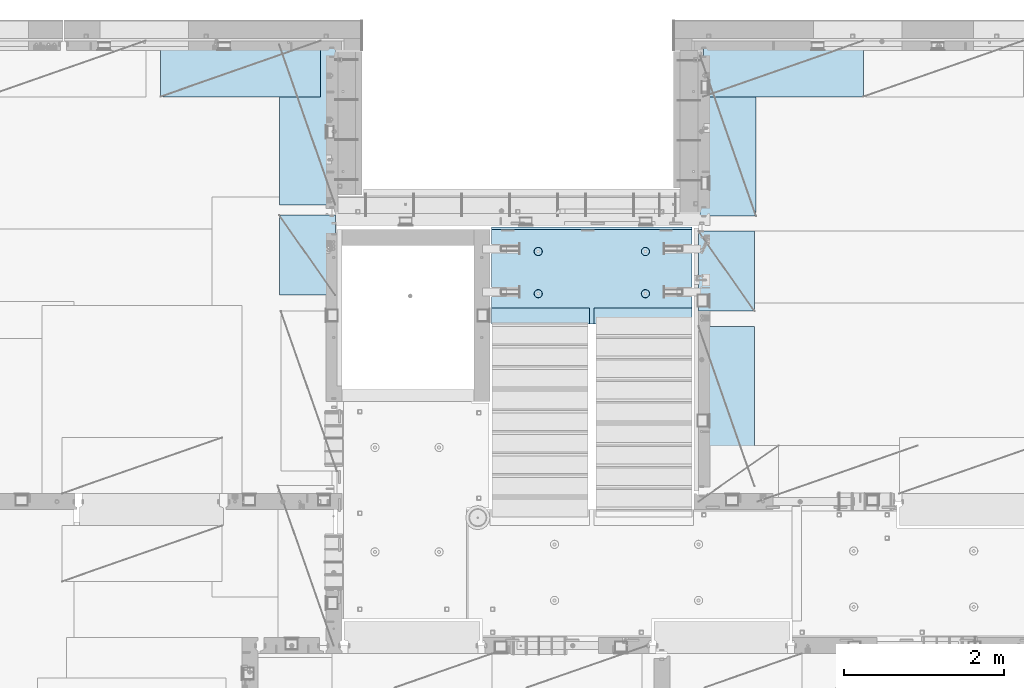
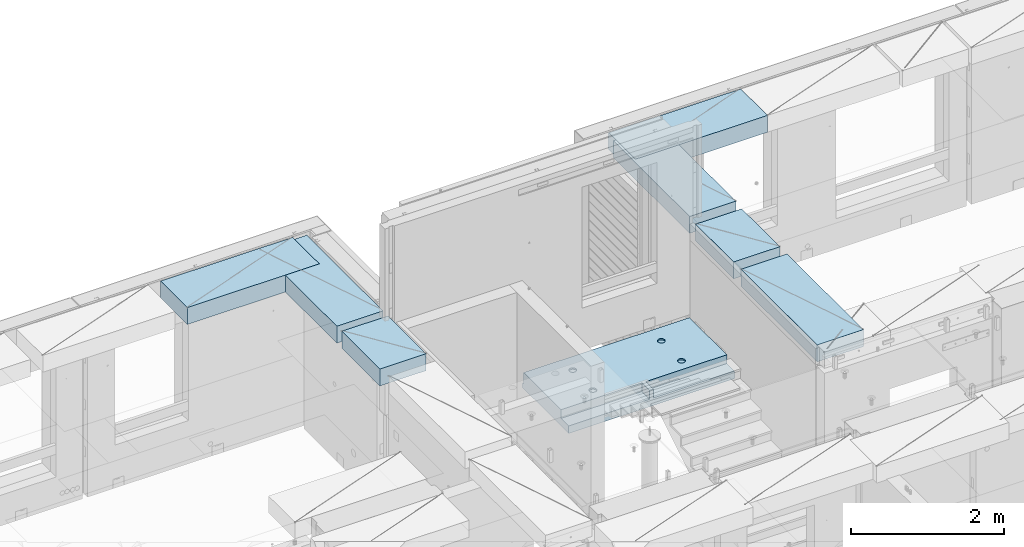
# One storey, part 208 of 349: 7 plates, 1 slab, 8 elements without a shape of their own.
"""IFC2X3 building model written with IfcOpenShell, lengths in millimetres."""

from ifc_helpers import new_model, si_unit, frame, origin_with_axes, place, context, subcontext, project, spatial, faceted_brep, material, type_object, element, aggregate, save


model = new_model("IFC2X3")

# Units and contexts
model_context = context("Model", 3, precision=1e-05, world=origin_with_axes())
body_context = subcontext(model_context, "Body", "Model", "MODEL_VIEW")
ifc_project = project(units=[si_unit("LENGTHUNIT", "METRE", prefix="MILLI"), si_unit("AREAUNIT", "SQUARE_METRE"), si_unit("VOLUMEUNIT", "CUBIC_METRE"), si_unit("MASSUNIT", "GRAM", prefix="KILO"), si_unit("TIMEUNIT", "SECOND"), si_unit("PLANEANGLEUNIT", "RADIAN"), si_unit("SOLIDANGLEUNIT", "STERADIAN"), si_unit("THERMODYNAMICTEMPERATUREUNIT", "DEGREE_CELSIUS"), si_unit("LUMINOUSINTENSITYUNIT", "LUMEN")], contexts=[model_context])

# Site, building, storey
site_placement = place(None, origin_with_axes())
site = spatial("IfcSite", under=ifc_project, at=site_placement, CompositionType="ELEMENT")
building_placement = place(site_placement, origin_with_axes())
building = spatial("IfcBuilding", under=site, at=building_placement, CompositionType="ELEMENT")
storey_placement = place(building_placement, origin_with_axes())
storey = spatial("IfcBuildingStorey", under=building, at=storey_placement, Name="4", CompositionType="ELEMENT", Elevation=0.0)

# Assembly, slab
assembly_1_placement = place(storey_placement, origin_with_axes())
assembly_1 = element("IfcElementAssembly", 1, at=assembly_1_placement, inside=storey, AssemblyPlace="NOTDEFINED", PredefinedType="REINFORCEMENT_UNIT")
ifc_material_1 = material(Name="CONCRETE/C25/30")
slab_type = type_object("IfcSlabType", PredefinedType="NOTDEFINED")
slab_placement = place(assembly_1_placement, frame((19680.000385927, 19200.0003517906, 92120.0), z_axis=(0.0, 1.0, 0.0), x_axis=(1.0, 0.0, 0.0)))
slab = element("IfcSlab", 2, at=slab_placement, type_object=slab_type, material=ifc_material_1, PredefinedType="FLOOR", context=body_context, shape_type="Brep", body=[
    faceted_brep([(1284.99890682963, -130.0, 0.0), (1284.99890682963, 10.0003972196719, 0.0), (1284.99890682963, 10.0003972196719, 200.003967285156), (1284.99890682963, -130.0, 200.003967285156), (2510.00073788432, 10.0003972196719, 200.003967285156), (2509.998046875, 10.0003972196719, 0.0), (2510.00073788432, -130.0, 200.003967285156), (2509.998046875, 60.0, 1210.00146484375), (0.0, 60.0, 1210.00146484375), (0.0, 50.0000001803419, 1180.00146538467), (2509.998046875, 50.0000001803419, 1180.00146538467), (2509.998046875, 130.0, 1210.00146484375), (0.0, 130.0, 1210.00146484375), (2509.998046875, 130.0, 0.0), (0.0, 130.0, -1.81898940354586e-12), (1225.00073788432, 10.0003972196719, 0.0), (1225.00073788432, 10.0003972196719, 200.003967285156), (-0.00109317036549328, 10.0003972196719, 200.003967285156), (0.0, 10.0003972196719, 0.0), (1225.00073788432, -130.0, 200.003967285156), (1225.00073788432, -130.0, 0.0), (0.0, -130.0, 200.003967285156), (0.0, -130.0, 1180.00146417833), (2509.998046875, -130.0, 1180.00146417833), (1940.44809334572, -110.0, 331.258272818675), (1954.3865062416, -110.0, 338.360248914683), (1965.44809334572, -110.0, 349.42183601881), (1972.55006944173, -110.0, 363.360248914683), (1974.99724362697, -110.0, 378.811098633432), (1972.55006944173, -110.0, 394.261948352181), (1965.44809334572, -110.0, 408.200361248055), (1954.3865062416, -110.0, 419.261948352181), (1940.44809334572, -110.0, 426.363924448189), (1924.99724362697, -110.0, 428.811098633432), (1909.54639390823, -110.0, 426.363924448189), (1895.60798101235, -110.0, 419.261948352181), (1884.54639390823, -110.0, 408.200361248055), (1877.44441781222, -110.0, 394.261948352181), (1874.99724362697, -110.0, 378.811098633432), (1877.44441781222, -110.0, 363.360248914683), (1884.54639390823, -110.0, 349.42183601881), (1895.60798101235, -110.0, 338.360248914683), (1909.54639390823, -110.0, 331.258272818675), (1924.99724362697, -110.0, 328.811098633432), (1974.71156152422, -130.0, 394.964259703032), (1977.2699708997, -130.0, 378.811098633432), (1967.28676833294, -130.0, 409.536236821448), (1955.72238181499, -130.0, 421.100623339393), (1941.15040469657, -130.0, 428.52541653068), (1924.99724362697, -130.0, 431.08382590616), (1908.84408255737, -130.0, 428.52541653068), (1894.27210543896, -130.0, 421.100623339393), (1882.70771892101, -130.0, 409.536236821448), (1875.28292572973, -130.0, 394.964259703032), (1872.72451635425, -130.0, 378.811098633432), (1875.28292572973, -130.0, 362.657937563832), (1882.70771892101, -130.0, 348.085960445416), (1894.27210543896, -130.0, 336.521573927472), (1908.84408255737, -130.0, 329.096780736185), (1924.99724362697, -130.0, 326.538371360704), (1941.15040469657, -130.0, 329.096780736185), (1955.72238181499, -130.0, 336.521573927472), (1967.28676833294, -130.0, 348.085960445416), (1974.71156152422, -130.0, 362.657937563832), (1940.44809334572, -110.0, 858.458272818676), (1954.3865062416, -110.0, 865.560248914684), (1965.44809334572, -110.0, 876.62183601881), (1972.55006944173, -110.0, 890.560248914684), (1974.99724362697, -110.0, 906.011098633433), (1972.55006944173, -110.0, 921.461948352182), (1965.44809334572, -110.0, 935.400361248056), (1954.3865062416, -110.0, 946.461948352182), (1940.44809334572, -110.0, 953.56392444819), (1924.99724362697, -110.0, 956.011098633433), (1909.54639390823, -110.0, 953.56392444819), (1895.60798101235, -110.0, 946.461948352182), (1884.54639390823, -110.0, 935.400361248056), (1877.44441781222, -110.0, 921.461948352182), (1874.99724362697, -110.0, 906.011098633433), (1877.44441781222, -110.0, 890.560248914684), (1884.54639390823, -110.0, 876.62183601881), (1895.60798101235, -110.0, 865.560248914684), (1909.54639390823, -110.0, 858.458272818676), (1924.99724362697, -110.0, 856.011098633433), (1974.71156152422, -130.0, 922.164259703033), (1977.2699708997, -130.0, 906.011098633433), (1967.28676833294, -130.0, 936.736236821449), (1955.72238181499, -130.0, 948.300623339394), (1941.15040469657, -130.0, 955.72541653068), (1924.99724362697, -130.0, 958.283825906161), (1908.84408255737, -130.0, 955.72541653068), (1894.27210543896, -130.0, 948.300623339394), (1882.70771892101, -130.0, 936.736236821449), (1875.28292572973, -130.0, 922.164259703033), (1872.72451635425, -130.0, 906.011098633433), (1875.28292572973, -130.0, 889.857937563833), (1882.70771892101, -130.0, 875.285960445417), (1894.27210543896, -130.0, 863.721573927472), (1908.84408255737, -130.0, 856.296780736186), (1924.99724362697, -130.0, 853.738371360705), (1941.15040469657, -130.0, 856.296780736186), (1955.72238181499, -130.0, 863.721573927472), (1967.28676833294, -130.0, 875.285960445417), (1974.71156152422, -130.0, 889.857937563833), (569.611134800252, -110.0, 426.363924448189), (555.672721904379, -110.0, 419.261948352181), (544.611134800252, -110.0, 408.200361248055), (537.509158704244, -110.0, 394.261948352181), (535.061984519001, -110.0, 378.811098633432), (537.509158704244, -110.0, 363.360248914683), (544.611134800252, -110.0, 349.42183601881), (555.672721904379, -110.0, 338.360248914683), (569.611134800252, -110.0, 331.258272818675), (585.061984519001, -110.0, 328.811098633432), (600.51283423775, -110.0, 331.258272818675), (614.451247133624, -110.0, 338.360248914683), (625.51283423775, -110.0, 349.42183601881), (632.614810333758, -110.0, 363.360248914683), (635.061984519001, -110.0, 378.811098633432), (632.614810333758, -110.0, 394.261948352181), (625.51283423775, -110.0, 408.200361248055), (614.451247133624, -110.0, 419.261948352181), (600.51283423775, -110.0, 426.363924448189), (585.061984519001, -110.0, 428.811098633432), (634.776302416249, -130.0, 394.964259703032), (637.334711791729, -130.0, 378.811098633432), (627.351509224962, -130.0, 409.536236821448), (615.787122707017, -130.0, 421.100623339393), (601.215145588601, -130.0, 428.52541653068), (585.061984519001, -130.0, 431.08382590616), (568.908823449401, -130.0, 428.52541653068), (554.336846330985, -130.0, 421.100623339393), (542.772459813041, -130.0, 409.536236821448), (535.347666621754, -130.0, 394.964259703032), (532.789257246273, -130.0, 378.811098633432), (535.347666621754, -130.0, 362.657937563832), (542.772459813041, -130.0, 348.085960445416), (554.336846330985, -130.0, 336.521573927472), (568.908823449401, -130.0, 329.096780736185), (585.061984519001, -130.0, 326.538371360704), (601.215145588601, -130.0, 329.096780736185), (615.787122707017, -130.0, 336.521573927472), (627.351509224962, -130.0, 348.085960445416), (634.776302416249, -130.0, 362.657937563832), (569.611134800252, -110.0, 953.56392444819), (555.672721904379, -110.0, 946.461948352182), (544.611134800252, -110.0, 935.400361248056), (537.509158704244, -110.0, 921.461948352182), (535.061984519001, -110.0, 906.011098633433), (537.509158704244, -110.0, 890.560248914684), (544.611134800252, -110.0, 876.62183601881), (555.672721904379, -110.0, 865.560248914684), (569.611134800252, -110.0, 858.458272818676), (585.061984519001, -110.0, 856.011098633433), (600.51283423775, -110.0, 858.458272818676), (614.451247133624, -110.0, 865.560248914684), (625.51283423775, -110.0, 876.62183601881), (632.614810333758, -110.0, 890.560248914684), (635.061984519001, -110.0, 906.011098633433), (632.614810333758, -110.0, 921.461948352182), (625.51283423775, -110.0, 935.400361248056), (614.451247133624, -110.0, 946.461948352182), (600.51283423775, -110.0, 953.56392444819), (585.061984519001, -110.0, 956.011098633433), (634.776302416249, -130.0, 922.164259703033), (637.334711791729, -130.0, 906.011098633433), (627.351509224962, -130.0, 936.736236821449), (615.787122707017, -130.0, 948.300623339394), (601.215145588601, -130.0, 955.72541653068), (585.061984519001, -130.0, 958.283825906161), (568.908823449401, -130.0, 955.72541653068), (554.336846330985, -130.0, 948.300623339394), (542.772459813041, -130.0, 936.736236821449), (535.347666621754, -130.0, 922.164259703033), (532.789257246273, -130.0, 906.011098633433), (535.347666621754, -130.0, 889.857937563833), (542.772459813041, -130.0, 875.285960445417), (554.336846330985, -130.0, 863.721573927472), (568.908823449401, -130.0, 856.296780736186), (585.061984519001, -130.0, 853.738371360705), (601.215145588601, -130.0, 856.296780736186), (615.787122707017, -130.0, 863.721573927472), (627.351509224962, -130.0, 875.285960445417), (634.776302416249, -130.0, 889.857937563833)], [[[0, 1, 2, 3]], [[4, 2, 1, 5]], [[6, 3, 2, 4]], [[7, 8, 9, 10]], [[11, 12, 8, 7]], [[11, 13, 14, 12]], [[15, 16, 17, 18]], [[19, 16, 15, 20]], [[21, 17, 16, 19]], [[22, 9, 8, 12, 14, 18, 17, 21]], [[23, 10, 9, 22]], [[5, 13, 11, 7, 10, 23, 6, 4]], [[0, 20, 15, 18, 14, 13, 5, 1]], [[24, 25, 26, 27, 28, 29, 30, 31, 32, 33, 34, 35, 36, 37, 38, 39, 40, 41, 42, 43]], [[44, 29, 28, 45]], [[46, 30, 29, 44]], [[47, 31, 30, 46]], [[48, 32, 31, 47]], [[49, 33, 32, 48]], [[50, 34, 33, 49]], [[51, 35, 34, 50]], [[52, 36, 35, 51]], [[53, 37, 36, 52]], [[54, 38, 37, 53]], [[55, 39, 38, 54]], [[56, 40, 39, 55]], [[57, 41, 40, 56]], [[58, 42, 41, 57]], [[59, 43, 42, 58]], [[60, 24, 43, 59]], [[61, 25, 24, 60]], [[62, 26, 25, 61]], [[63, 27, 26, 62]], [[45, 28, 27, 63]], [[64, 65, 66, 67, 68, 69, 70, 71, 72, 73, 74, 75, 76, 77, 78, 79, 80, 81, 82, 83]], [[84, 69, 68, 85]], [[86, 70, 69, 84]], [[87, 71, 70, 86]], [[88, 72, 71, 87]], [[89, 73, 72, 88]], [[90, 74, 73, 89]], [[91, 75, 74, 90]], [[92, 76, 75, 91]], [[93, 77, 76, 92]], [[94, 78, 77, 93]], [[95, 79, 78, 94]], [[96, 80, 79, 95]], [[97, 81, 80, 96]], [[98, 82, 81, 97]], [[99, 83, 82, 98]], [[100, 64, 83, 99]], [[101, 65, 64, 100]], [[102, 66, 65, 101]], [[103, 67, 66, 102]], [[85, 68, 67, 103]], [[104, 105, 106, 107, 108, 109, 110, 111, 112, 113, 114, 115, 116, 117, 118, 119, 120, 121, 122, 123]], [[124, 119, 118, 125]], [[126, 120, 119, 124]], [[127, 121, 120, 126]], [[128, 122, 121, 127]], [[129, 123, 122, 128]], [[130, 104, 123, 129]], [[131, 105, 104, 130]], [[132, 106, 105, 131]], [[133, 107, 106, 132]], [[134, 108, 107, 133]], [[135, 109, 108, 134]], [[136, 110, 109, 135]], [[137, 111, 110, 136]], [[138, 112, 111, 137]], [[139, 113, 112, 138]], [[140, 114, 113, 139]], [[141, 115, 114, 140]], [[142, 116, 115, 141]], [[143, 117, 116, 142]], [[125, 118, 117, 143]], [[144, 145, 146, 147, 148, 149, 150, 151, 152, 153, 154, 155, 156, 157, 158, 159, 160, 161, 162, 163]], [[164, 159, 158, 165]], [[166, 160, 159, 164]], [[167, 161, 160, 166]], [[168, 162, 161, 167]], [[169, 163, 162, 168]], [[170, 144, 163, 169]], [[171, 145, 144, 170]], [[172, 146, 145, 171]], [[173, 147, 146, 172]], [[174, 148, 147, 173]], [[175, 149, 148, 174]], [[176, 150, 149, 175]], [[177, 151, 150, 176]], [[178, 152, 151, 177]], [[179, 153, 152, 178]], [[180, 154, 153, 179]], [[181, 155, 154, 180]], [[182, 156, 155, 181]], [[183, 157, 156, 182]], [[165, 158, 157, 183]], [[23, 22, 21, 19, 20, 0, 3, 6], [182, 181, 180, 179, 178, 177, 176, 175, 174, 173, 172, 171, 170, 169, 168, 167, 166, 164, 165, 183], [142, 141, 140, 139, 138, 137, 136, 135, 134, 133, 132, 131, 130, 129, 128, 127, 126, 124, 125, 143], [102, 101, 100, 99, 98, 97, 96, 95, 94, 93, 92, 91, 90, 89, 88, 87, 86, 84, 85, 103], [62, 61, 60, 59, 58, 57, 56, 55, 54, 53, 52, 51, 50, 49, 48, 47, 46, 44, 45, 63]]]),
])
aggregate(assembly_1, [slab])

# Assembly, plate
assembly_2_placement = place(storey_placement, origin_with_axes())
assembly_2 = element("IfcElementAssembly", 3, at=assembly_2_placement, inside=storey, Name="Steel Assembly", AssemblyPlace="NOTDEFINED", PredefinedType="NOTDEFINED")
ifc_material_2 = material()
plate_type = type_object("IfcPlateType", PredefinedType="NOTDEFINED")
plate_1_placement = place(assembly_2_placement, frame((24330.0, 22740.0001220703, 93595.3), z_axis=(0.0, -1.0, 0.0), x_axis=(-1.0, 3.00000001838171e-08, 0.0)))
plate_1 = element("IfcPlate", 4, at=plate_1_placement, type_object=plate_type, material=ifc_material_2, Name="RE1", context=body_context, shape_type="Brep", body=[
    faceted_brep([(1.81898940354586e-12, -135.0, 1.81898940354586e-12), (0.0, -135.0, 699.999999999996), (0.0, 135.0, 699.999999999996), (1.81898940354586e-12, 135.0, 1.81898940354586e-12), (1999.99951171875, -135.0, 699.999999999993), (1999.99951171875, 135.0, 699.999999999993), (2000.0, -135.0, -3.63797880709171e-12), (2000.0, 135.0, -3.63797880709171e-12)], [[[0, 1, 2, 3]], [[1, 4, 5, 2]], [[4, 6, 7, 5]], [[6, 0, 3, 7]], [[5, 7, 3, 2]], [[6, 4, 1, 0]]]),
])
aggregate(assembly_2, [plate_1])

assembly_3_placement = place(storey_placement, origin_with_axes())
assembly_3 = element("IfcElementAssembly", 5, at=assembly_3_placement, inside=storey, Name="Steel Assembly", AssemblyPlace="NOTDEFINED", PredefinedType="NOTDEFINED")
plate_2_placement = place(assembly_3_placement, frame((17730.0001220703, 20690.0, 93595.3), z_axis=(-1.0, 3.00000001838171e-08, 0.0), x_axis=(0.0, 1.0, 0.0)))
plate_2 = element("IfcPlate", 6, at=plate_2_placement, type_object=plate_type, material=ifc_material_2, Name="RE1", context=body_context, shape_type="Brep", body=[
    faceted_brep([(1.81898940354586e-12, -135.0, 1.81898940354586e-12), (0.0, -135.0, 699.999999999996), (0.0, 135.0, 699.999999999996), (1.81898940354586e-12, 135.0, 1.81898940354586e-12), (1999.99951171875, -135.0, 699.999999999993), (1999.99951171875, 135.0, 699.999999999993), (2000.0, -135.0, -3.63797880709171e-12), (2000.0, 135.0, -3.63797880709171e-12)], [[[0, 1, 2, 3]], [[1, 4, 5, 2]], [[4, 6, 7, 5]], [[6, 0, 3, 7]], [[5, 7, 3, 2]], [[6, 4, 1, 0]]]),
])
aggregate(assembly_3, [plate_2])

assembly_4_placement = place(storey_placement, origin_with_axes())
assembly_4 = element("IfcElementAssembly", 7, at=assembly_4_placement, inside=storey, Name="Steel Assembly", AssemblyPlace="NOTDEFINED", PredefinedType="NOTDEFINED")
plate_3_placement = place(assembly_4_placement, frame((22269.9998779297, 19170.0, 93595.3), z_axis=(1.0, 0.0, 0.0), x_axis=(0.0, -1.0, 0.0)))
plate_3 = element("IfcPlate", 8, at=plate_3_placement, type_object=plate_type, material=ifc_material_2, Name="RE1", context=body_context, shape_type="Brep", body=[
    faceted_brep([(1.81898940354586e-12, -135.0, 1.81898940354586e-12), (0.0, -135.0, 699.999999999996), (0.0, 135.0, 699.999999999996), (1.81898940354586e-12, 135.0, 1.81898940354586e-12), (1999.99951171875, -135.0, 699.999999999993), (1999.99951171875, 135.0, 699.999999999993), (2000.0, -135.0, -3.63797880709171e-12), (2000.0, 135.0, -3.63797880709171e-12)], [[[0, 1, 2, 3]], [[1, 4, 5, 2]], [[4, 6, 7, 5]], [[6, 0, 3, 7]], [[5, 7, 3, 2]], [[6, 4, 1, 0]]]),
])
aggregate(assembly_4, [plate_3])

assembly_5_placement = place(storey_placement, origin_with_axes())
assembly_5 = element("IfcElementAssembly", 9, at=assembly_5_placement, inside=storey, Name="Steel Assembly", AssemblyPlace="NOTDEFINED", PredefinedType="NOTDEFINED")
plate_4_placement = place(assembly_5_placement, frame((22289.9998779297, 22550.0, 93595.3), z_axis=(1.0, 0.0, 0.0), x_axis=(0.0, -1.0, 0.0)))
plate_4 = element("IfcPlate", 10, at=plate_4_placement, type_object=plate_type, material=ifc_material_2, Name="RE1", context=body_context, shape_type="Brep", body=[
    faceted_brep([(1.81898940354586e-12, -135.0, 1.81898940354586e-12), (0.0, -135.0, 699.999999999996), (0.0, 135.0, 699.999999999996), (1.81898940354586e-12, 135.0, 1.81898940354586e-12), (1999.99951171875, -135.0, 699.999999999993), (1999.99951171875, 135.0, 699.999999999993), (2000.0, -135.0, -3.63797880709171e-12), (2000.0, 135.0, -3.63797880709171e-12)], [[[0, 1, 2, 3]], [[1, 4, 5, 2]], [[4, 6, 7, 5]], [[6, 0, 3, 7]], [[5, 7, 3, 2]], [[6, 4, 1, 0]]]),
])
aggregate(assembly_5, [plate_4])

assembly_6_placement = place(storey_placement, origin_with_axes())
assembly_6 = element("IfcElementAssembly", 11, at=assembly_6_placement, inside=storey, Name="Steel Assembly", AssemblyPlace="NOTDEFINED", PredefinedType="NOTDEFINED")
plate_5_placement = place(assembly_6_placement, frame((22269.9999999293, 20360.0, 93595.3), z_axis=(1.0, 0.0, 0.0), x_axis=(0.0, -1.0, 0.0)))
plate_5 = element("IfcPlate", 12, at=plate_5_placement, type_object=plate_type, material=ifc_material_2, Name="RE1_1/2", context=body_context, shape_type="Brep", body=[
    faceted_brep([(1.81898940354586e-12, -135.0, 1.81898940354586e-12), (0.0, -135.0, 699.999999999996), (0.0, 135.0, 699.999999999996), (1.81898940354586e-12, 135.0, 1.81898940354586e-12), (999.99951171875, -135.0, 700.0), (999.99951171875, 135.0, 700.0), (1000.0, -135.0, 0.0), (1000.0, 135.0, 0.0)], [[[0, 1, 2, 3]], [[1, 4, 5, 2]], [[4, 6, 7, 5]], [[6, 0, 3, 7]], [[5, 7, 3, 2]], [[6, 4, 1, 0]]]),
])
aggregate(assembly_6, [plate_5])

assembly_7_placement = place(storey_placement, origin_with_axes())
assembly_7 = element("IfcElementAssembly", 13, at=assembly_7_placement, inside=storey, Name="Steel Assembly", AssemblyPlace="NOTDEFINED", PredefinedType="NOTDEFINED")
plate_6_placement = place(assembly_7_placement, frame((17730.0000000707, 19560.0, 93595.3), z_axis=(-1.0, 3.00000001838171e-08, 0.0), x_axis=(0.0, 1.0, 0.0)))
plate_6 = element("IfcPlate", 14, at=plate_6_placement, type_object=plate_type, material=ifc_material_2, Name="RE1_1/2", context=body_context, shape_type="Brep", body=[
    faceted_brep([(1.81898940354586e-12, -135.0, 1.81898940354586e-12), (0.0, -135.0, 699.999999999996), (0.0, 135.0, 699.999999999996), (1.81898940354586e-12, 135.0, 1.81898940354586e-12), (999.99951171875, -135.0, 700.0), (999.99951171875, 135.0, 700.0), (1000.0, -135.0, 0.0), (1000.0, 135.0, 0.0)], [[[0, 1, 2, 3]], [[1, 4, 5, 2]], [[4, 6, 7, 5]], [[6, 0, 3, 7]], [[5, 7, 3, 2]], [[6, 4, 1, 0]]]),
])
aggregate(assembly_7, [plate_6])

assembly_8_placement = place(storey_placement, origin_with_axes())
assembly_8 = element("IfcElementAssembly", 15, at=assembly_8_placement, inside=storey, Name="Steel Assembly", AssemblyPlace="NOTDEFINED", PredefinedType="NOTDEFINED")
plate_7_placement = place(assembly_8_placement, frame((17545.0, 22740.0001220703, 93595.3), z_axis=(0.0, -1.0, 0.0), x_axis=(-1.0, 3.00000001838171e-08, 0.0)))
plate_7 = element("IfcPlate", 16, at=plate_7_placement, type_object=plate_type, material=ifc_material_2, Name="RE1", context=body_context, shape_type="Brep", body=[
    faceted_brep([(1.81898940354586e-12, -135.0, 1.81898940354586e-12), (0.0, -135.0, 699.999999999996), (0.0, 135.0, 699.999999999996), (1.81898940354586e-12, 135.0, 1.81898940354586e-12), (1999.99951171875, -135.0, 699.999999999993), (1999.99951171875, 135.0, 699.999999999993), (2000.0, -135.0, -3.63797880709171e-12), (2000.0, 135.0, -3.63797880709171e-12)], [[[0, 1, 2, 3]], [[1, 4, 5, 2]], [[4, 6, 7, 5]], [[6, 0, 3, 7]], [[5, 7, 3, 2]], [[6, 4, 1, 0]]]),
])
aggregate(assembly_8, [plate_7])

save(model, "model.ifc")
